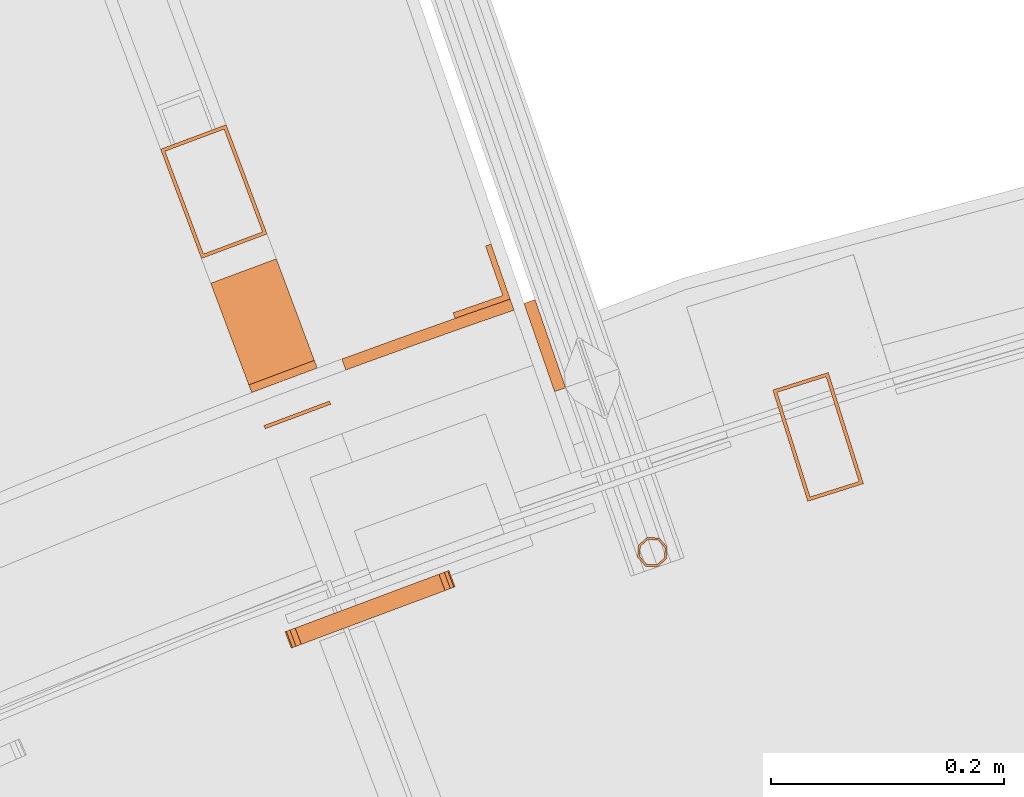
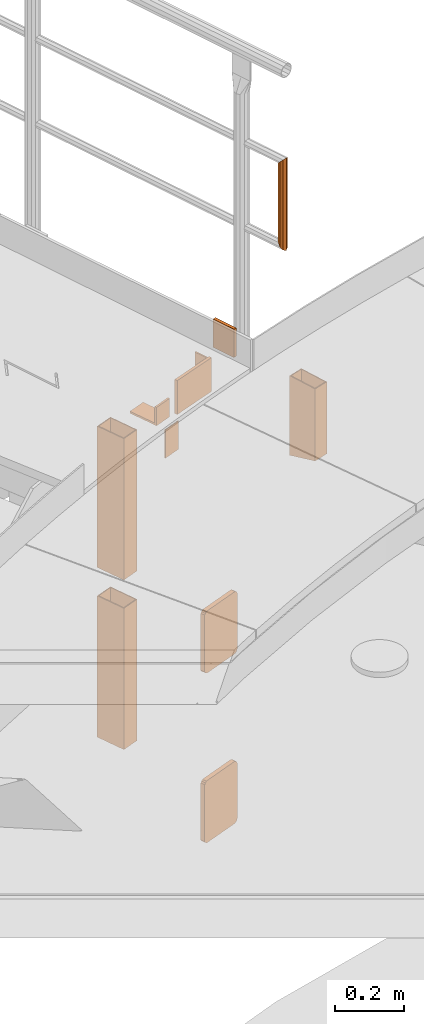
# One storey, part 88 of 126: 11 proxies.
"""IFC2X3 building model written with IfcOpenShell, lengths in millimetres."""

from ifc_helpers import new_model, si_unit, origin, origin_with_axes, place, context, project, spatial, faceted_brep, material, element, save


model = new_model("IFC2X3")

# Units and contexts
context_of_model_1 = context(None, 3, precision=0.1, world=origin())
context_of_model_2 = context(None, 3, precision=0.1, world=origin())
ifc_project = project(units=[si_unit("LENGTHUNIT", "METRE", prefix="MILLI"), si_unit("AREAUNIT", "SQUARE_METRE", prefix="CENTI"), si_unit("VOLUMEUNIT", "CUBIC_METRE", prefix="CENTI"), si_unit("MASSUNIT", "GRAM", prefix="KILO")], contexts=[context_of_model_1, context_of_model_2])

# Site, building, storey
site_placement = place(None, origin_with_axes())
site = spatial("IfcSite", under=ifc_project, at=site_placement, CompositionType="ELEMENT")
building_placement = place(site_placement, origin_with_axes())
building = spatial("IfcBuilding", under=site, at=building_placement, CompositionType="ELEMENT")
storey_placement = place(building_placement, origin_with_axes())
storey = spatial("IfcBuildingStorey", under=building, at=storey_placement, CompositionType="ELEMENT")

# Proxies
ifc_material_1 = material(Name="STAHL")
proxy_1_placement = place(storey_placement, origin_with_axes())
element("IfcBuildingElementProxy", 1, at=proxy_1_placement, inside=storey, material=ifc_material_1, Name="profile", context=context_of_model_2, shape_type="Brep", body=[
    faceted_brep([(5614.6, 15503.4, 10673.4), (5644.6, 15408.0, 10700.2), (5644.6, 15408.0, 10955.2), (5614.6, 15503.4, 10955.2), (5692.3, 15423.1, 10700.2), (5692.3, 15423.1, 10955.2), (5662.2, 15518.4, 10673.4), (5662.2, 15518.4, 10955.2), (5646.6, 15411.8, 10699.4), (5618.3, 15501.4, 10674.2), (5618.3, 15501.4, 10955.2), (5646.6, 15411.8, 10955.2), (5660.3, 15514.7, 10674.2), (5660.3, 15514.7, 10955.2), (5688.5, 15425.0, 10699.4), (5688.5, 15425.0, 10955.2)], [[[0, 1, 2, 3]], [[1, 4, 5, 2]], [[4, 6, 7, 5]], [[6, 0, 3, 7]], [[8, 9, 10, 11]], [[9, 12, 13, 10]], [[12, 14, 15, 13]], [[14, 8, 11, 15]], [[1, 0, 6, 4], [9, 8, 14, 12]], [[2, 5, 7, 3], [15, 11, 10, 13]]]),
])
ifc_material_2 = material(Name="S235JRG2")
proxy_2_placement = place(storey_placement, origin_with_axes())
element("IfcBuildingElementProxy", 2, at=proxy_2_placement, inside=storey, material=ifc_material_2, context=context_of_model_2, shape_type="Brep", body=[
    faceted_brep([(5328.3656, 15329.482, 9575.15), (5333.7418, 15331.493, 9576.2918), (5338.2995, 15333.199, 9579.5434), (5341.3449, 15334.338, 9584.4097), (5342.4143, 15334.738, 9590.15), (5342.4143, 15334.738, 9780.15), (5341.3449, 15334.338, 9785.8902), (5338.2995, 15333.199, 9790.7566), (5333.7418, 15331.493, 9794.0082), (5328.3656, 15329.482, 9795.15), (5215.9759, 15287.427, 9795.15), (5210.5997, 15285.415, 9794.0082), (5206.042, 15283.71, 9790.7566), (5202.9966, 15282.571, 9785.8902), (5201.9272, 15282.17, 9780.15), (5201.9272, 15282.17, 9590.15), (5202.9966, 15282.571, 9584.4097), (5206.042, 15283.71, 9579.5434), (5210.5997, 15285.415, 9576.2918), (5215.9759, 15287.427, 9575.15), (5323.1088, 15343.53, 9575.15), (5210.7191, 15301.476, 9575.15), (5205.3429, 15299.464, 9576.2918), (5200.7852, 15297.759, 9579.5434), (5197.7398, 15296.619, 9584.4097), (5196.6704, 15296.219, 9590.15), (5196.6704, 15296.219, 9780.15), (5197.7398, 15296.619, 9785.8902), (5200.7852, 15297.759, 9790.7566), (5205.3429, 15299.464, 9794.0082), (5210.7191, 15301.476, 9795.15), (5323.1088, 15343.53, 9795.15), (5328.485, 15345.542, 9794.0082), (5333.0427, 15347.247, 9790.7566), (5336.0881, 15348.387, 9785.8902), (5337.1575, 15348.787, 9780.15), (5337.1575, 15348.787, 9590.15), (5336.0881, 15348.387, 9584.4097), (5333.0427, 15347.247, 9579.5434), (5328.485, 15345.542, 9576.2918)], [[[0, 1, 2, 3, 4, 5, 6, 7, 8, 9, 10, 11, 12, 13, 14, 15, 16, 17, 18, 19]], [[20, 21, 22, 23, 24, 25, 26, 27, 28, 29, 30, 31, 32, 33, 34, 35, 36, 37, 38, 39]], [[0, 20, 39, 1]], [[1, 39, 38, 2]], [[2, 38, 37, 3]], [[3, 37, 36, 4]], [[4, 36, 35, 5]], [[5, 35, 34, 6]], [[6, 34, 33, 7]], [[7, 33, 32, 8]], [[8, 32, 31, 9]], [[9, 31, 30, 10]], [[10, 30, 29, 11]], [[11, 29, 28, 12]], [[12, 28, 27, 13]], [[13, 27, 26, 14]], [[14, 26, 25, 15]], [[15, 25, 24, 16]], [[16, 24, 23, 17]], [[17, 23, 22, 18]], [[18, 22, 21, 19]], [[19, 21, 20, 0]]]),
])
proxy_3_placement = place(storey_placement, origin_with_axes())
element("IfcBuildingElementProxy", 3, at=proxy_3_placement, inside=storey, material=ifc_material_2, context=context_of_model_2, shape_type="Brep", body=[
    faceted_brep([(5168.021, 15501.19, 11000.15), (5168.021, 15501.19, 10935.15), (5224.2158, 15522.217, 10935.15), (5224.2158, 15522.217, 11000.15), (5221.7626, 15528.773, 11000.15), (5165.5678, 15507.746, 11000.15), (5221.7626, 15528.773, 10942.15), (5165.5678, 15507.746, 10942.15), (5189.1705, 15615.875, 10942.15), (5132.9757, 15594.848, 10942.15), (5189.1705, 15615.875, 10935.15), (5132.9757, 15594.848, 10935.15)], [[[0, 1, 2, 3]], [[0, 3, 4, 5]], [[5, 4, 6, 7]], [[7, 6, 8, 9]], [[9, 8, 10, 11]], [[1, 11, 10, 2]], [[1, 0, 5, 7, 9, 11]], [[3, 2, 10, 8, 6, 4]]]),
])
proxy_4_placement = place(storey_placement, origin_with_axes())
element("IfcBuildingElementProxy", 4, at=proxy_4_placement, inside=storey, material=ifc_material_2, context=context_of_model_2, shape_type="Brep", body=[
    faceted_brep([(5089.9889, 15709.73, 10835.15), (5146.1837, 15730.757, 10835.15), (5146.1835, 15730.758, 10335.15), (5089.9886, 15709.73, 10335.15), (5181.229, 15637.099, 10835.15), (5181.2287, 15637.1, 10335.15), (5125.0341, 15616.072, 10835.15), (5125.0339, 15616.072, 10335.15), (5093.85, 15707.971, 10835.15), (5126.7925, 15619.933, 10835.15), (5126.7923, 15619.933, 10335.15), (5093.8497, 15707.972, 10335.15), (5177.3679, 15638.857, 10835.15), (5177.3676, 15638.858, 10335.15), (5144.4253, 15726.896, 10835.15), (5144.4251, 15726.897, 10335.15)], [[[0, 1, 2, 3]], [[1, 4, 5, 2]], [[4, 6, 7, 5]], [[0, 3, 7, 6]], [[8, 9, 10, 11]], [[9, 12, 13, 10]], [[12, 14, 15, 13]], [[8, 11, 15, 14]], [[1, 0, 6, 4], [8, 14, 12, 9]], [[7, 3, 2, 5], [10, 13, 15, 11]]]),
])
proxy_5_placement = place(storey_placement, origin_with_axes())
element("IfcBuildingElementProxy", 5, at=proxy_5_placement, inside=storey, material=ifc_material_2, context=context_of_model_2, shape_type="Brep", body=[
    faceted_brep([(5089.9889, 15709.73, 10235.15), (5146.1837, 15730.757, 10235.15), (5146.1835, 15730.758, 9735.15), (5089.9886, 15709.73, 9735.15), (5181.229, 15637.099, 10235.15), (5181.2287, 15637.1, 9735.15), (5125.0341, 15616.072, 10235.15), (5125.0339, 15616.072, 9735.15), (5093.85, 15707.971, 10235.15), (5126.7925, 15619.933, 10235.15), (5126.7923, 15619.933, 9735.15), (5093.8497, 15707.972, 9735.15), (5177.3679, 15638.857, 10235.15), (5177.3676, 15638.858, 9735.15), (5144.4253, 15726.896, 10235.15), (5144.4251, 15726.897, 9735.15)], [[[0, 1, 2, 3]], [[1, 4, 5, 2]], [[4, 6, 7, 5]], [[0, 3, 7, 6]], [[8, 9, 10, 11]], [[9, 12, 13, 10]], [[12, 14, 15, 13]], [[8, 11, 15, 14]], [[1, 0, 6, 4], [8, 14, 12, 9]], [[7, 3, 2, 5], [10, 13, 15, 11]]]),
])
proxy_6_placement = place(storey_placement, origin_with_axes())
element("IfcBuildingElementProxy", 6, at=proxy_6_placement, inside=storey, material=ifc_material_2, context=context_of_model_2, shape_type="Brep", body=[
    faceted_brep([(5235.834, 15491.168, 10835.15), (5179.6392, 15470.14, 10835.15), (5178.5878, 15472.95, 10835.15), (5234.7827, 15493.977, 10835.15), (5235.834, 15491.168, 10935.15), (5234.7827, 15493.977, 10935.15), (5178.5878, 15472.95, 10935.15), (5179.6392, 15470.14, 10935.15)], [[[0, 1, 2, 3]], [[4, 5, 6, 7]], [[0, 3, 5, 4]], [[3, 2, 6, 5]], [[2, 1, 7, 6]], [[1, 0, 4, 7]]]),
])
proxy_7_placement = place(storey_placement, origin_with_axes())
element("IfcBuildingElementProxy", 7, at=proxy_7_placement, inside=storey, material=ifc_material_2, context=context_of_model_2, shape_type="Brep", body=[
    faceted_brep([(5328.3656, 15329.482, 10175.15), (5333.7418, 15331.493, 10176.292), (5338.2995, 15333.199, 10179.543), (5341.3449, 15334.338, 10184.41), (5342.4143, 15334.738, 10190.15), (5342.4143, 15334.738, 10380.15), (5341.3449, 15334.338, 10385.89), (5338.2995, 15333.199, 10390.757), (5333.7418, 15331.493, 10394.008), (5328.3656, 15329.482, 10395.15), (5215.9759, 15287.427, 10395.15), (5210.5997, 15285.415, 10394.008), (5206.042, 15283.71, 10390.757), (5202.9966, 15282.571, 10385.89), (5201.9272, 15282.17, 10380.15), (5201.9272, 15282.17, 10190.15), (5202.9966, 15282.571, 10184.41), (5206.042, 15283.71, 10179.543), (5210.5997, 15285.415, 10176.292), (5215.9759, 15287.427, 10175.15), (5323.1088, 15343.53, 10175.15), (5210.7191, 15301.476, 10175.15), (5205.3429, 15299.464, 10176.292), (5200.7852, 15297.759, 10179.543), (5197.7398, 15296.619, 10184.41), (5196.6704, 15296.219, 10190.15), (5196.6704, 15296.219, 10380.15), (5197.7398, 15296.619, 10385.89), (5200.7852, 15297.759, 10390.757), (5205.3429, 15299.464, 10394.008), (5210.7191, 15301.476, 10395.15), (5323.1088, 15343.53, 10395.15), (5328.485, 15345.542, 10394.008), (5333.0427, 15347.247, 10390.757), (5336.0881, 15348.387, 10385.89), (5337.1575, 15348.787, 10380.15), (5337.1575, 15348.787, 10190.15), (5336.0881, 15348.387, 10184.41), (5333.0427, 15347.247, 10179.543), (5328.485, 15345.542, 10176.292)], [[[0, 1, 2, 3, 4, 5, 6, 7, 8, 9, 10, 11, 12, 13, 14, 15, 16, 17, 18, 19]], [[20, 21, 22, 23, 24, 25, 26, 27, 28, 29, 30, 31, 32, 33, 34, 35, 36, 37, 38, 39]], [[0, 20, 39, 1]], [[1, 39, 38, 2]], [[2, 38, 37, 3]], [[3, 37, 36, 4]], [[4, 36, 35, 5]], [[5, 35, 34, 6]], [[6, 34, 33, 7]], [[7, 33, 32, 8]], [[8, 32, 31, 9]], [[9, 31, 30, 10]], [[10, 30, 29, 11]], [[11, 29, 28, 12]], [[12, 28, 27, 13]], [[13, 27, 26, 14]], [[14, 26, 25, 15]], [[15, 25, 24, 16]], [[16, 24, 23, 17]], [[17, 23, 22, 18]], [[18, 22, 21, 19]], [[19, 21, 20, 0]]]),
])
proxy_8_placement = place(storey_placement, origin_with_axes())
element("IfcBuildingElementProxy", 8, at=proxy_8_placement, inside=storey, material=ifc_material_2, context=context_of_model_2, shape_type="Brep", body=[
    faceted_brep([(5297.9076, 15549.018, 10935.15), (5301.2853, 15539.606, 10935.15), (5248.7505, 15520.546, 10935.15), (5245.3073, 15529.935, 10935.15), (5301.2853, 15539.606, 11055.0), (5248.7505, 15520.546, 11055.0), (5245.3073, 15529.935, 11055.0), (5297.9076, 15549.018, 11055.0), (5350.6401, 15567.734, 10935.15), (5353.952, 15558.298, 10935.15), (5353.952, 15558.298, 11055.0), (5350.6401, 15567.734, 11055.0), (5389.5711, 15581.246, 10935.15), (5392.8469, 15571.798, 10935.15), (5392.8469, 15571.798, 11055.0), (5389.5711, 15581.246, 11055.0)], [[[0, 1, 2, 3]], [[1, 4, 5, 2]], [[0, 3, 6, 7]], [[0, 8, 9, 1]], [[1, 9, 10, 4]], [[0, 7, 11, 8]], [[8, 12, 13, 9]], [[9, 13, 14, 10]], [[8, 11, 15, 12]], [[5, 4, 10, 14, 15, 11, 7, 6]], [[12, 15, 14, 13]], [[2, 5, 6, 3]]]),
])
proxy_9_placement = place(storey_placement, origin_with_axes())
element("IfcBuildingElementProxy", 9, at=proxy_9_placement, inside=storey, material=ifc_material_2, context=context_of_model_2, shape_type="Brep", body=[
    faceted_brep([(5515.8661, 15351.755, 11851.605), (5505.5898, 15352.362, 11847.666), (5505.5898, 15352.362, 11528.645), (5515.8661, 15351.755, 11524.705), (5498.7523, 15360.057, 11838.155), (5498.7523, 15360.057, 11538.155), (5499.3588, 15370.334, 11828.645), (5499.3588, 15370.334, 11547.666), (5507.0542, 15377.171, 11824.705), (5507.0542, 15377.171, 11551.605), (5517.3305, 15376.565, 11828.645), (5517.3305, 15376.565, 11547.666), (5524.168, 15368.869, 11838.155), (5524.168, 15368.869, 11538.155), (5523.5614, 15358.593, 11847.666), (5523.5614, 15358.593, 11528.645), (5515.2109, 15353.645, 11849.605), (5521.762, 15359.466, 11846.252), (5521.762, 15359.466, 11530.059), (5515.2109, 15353.645, 11526.705), (5522.2784, 15368.214, 11838.155), (5522.2784, 15368.214, 11538.155), (5516.4576, 15374.765, 11830.059), (5516.4576, 15374.765, 11546.251), (5507.7094, 15375.282, 11826.705), (5507.7094, 15375.282, 11549.605), (5501.1583, 15369.461, 11830.059), (5501.1583, 15369.461, 11546.251), (5500.6419, 15360.713, 11838.155), (5500.6419, 15360.713, 11538.155), (5506.4627, 15354.162, 11846.252), (5506.4627, 15354.162, 11530.059)], [[[0, 1, 2, 3]], [[1, 4, 5, 2]], [[4, 6, 7, 5]], [[6, 8, 9, 7]], [[8, 10, 11, 9]], [[10, 12, 13, 11]], [[12, 14, 15, 13]], [[0, 3, 15, 14]], [[16, 17, 18, 19]], [[17, 20, 21, 18]], [[20, 22, 23, 21]], [[22, 24, 25, 23]], [[24, 26, 27, 25]], [[26, 28, 29, 27]], [[28, 30, 31, 29]], [[16, 19, 31, 30]], [[12, 10, 8, 6, 4, 1, 0, 14], [16, 30, 28, 26, 24, 22, 20, 17]], [[3, 2, 5, 7, 9, 11, 13, 15], [18, 21, 23, 25, 27, 29, 31, 19]]]),
])
proxy_10_placement = place(storey_placement, origin_with_axes())
element("IfcBuildingElementProxy", 10, at=proxy_10_placement, inside=storey, material=ifc_material_2, Name="HANDLAUF", context=context_of_model_2, shape_type="Brep", body=[
    faceted_brep([(5427.6266, 15502.025, 11085.15), (5401.4167, 15577.61, 11085.15), (5410.8648, 15580.886, 11085.15), (5437.0747, 15505.302, 11085.15), (5427.6266, 15502.025, 11185.15), (5437.0747, 15505.302, 11185.15), (5410.8648, 15580.886, 11185.15), (5401.4167, 15577.61, 11185.15)], [[[0, 1, 2, 3]], [[4, 5, 6, 7]], [[0, 3, 5, 4]], [[3, 2, 6, 5]], [[2, 1, 7, 6]], [[1, 0, 4, 7]]]),
])
proxy_11_placement = place(storey_placement, origin_with_axes())
element("IfcBuildingElementProxy", 11, at=proxy_11_placement, inside=storey, material=ifc_material_2, Name="HANDLAUF", context=context_of_model_2, shape_type="Brep", body=[
    faceted_brep([(5342.3351, 15564.852, 10940.0), (5389.5713, 15581.246, 10940.0), (5389.5713, 15581.246, 11050.0), (5342.3351, 15564.852, 11050.0), (5340.6957, 15569.576, 11050.0), (5340.6957, 15569.576, 10940.0), (5383.2083, 15584.33, 11050.0), (5383.2083, 15584.33, 10940.0), (5368.4543, 15626.843, 11050.0), (5368.4543, 15626.843, 10940.0), (5373.1779, 15628.482, 11050.0), (5373.1779, 15628.482, 10940.0)], [[[0, 1, 2, 3]], [[0, 3, 4, 5]], [[5, 4, 6, 7]], [[7, 6, 8, 9]], [[9, 8, 10, 11]], [[1, 11, 10, 2]], [[1, 0, 5, 7, 9, 11]], [[3, 2, 10, 8, 6, 4]]]),
])

save(model, "model.ifc")
